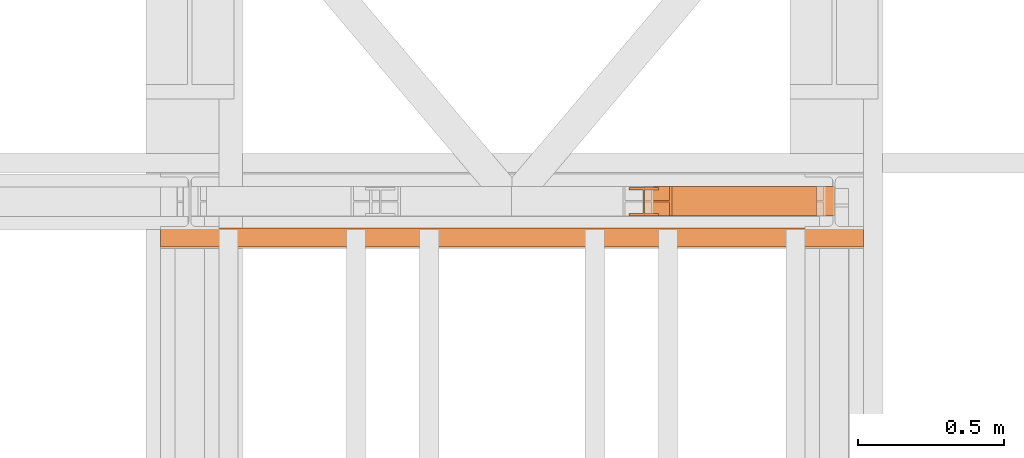
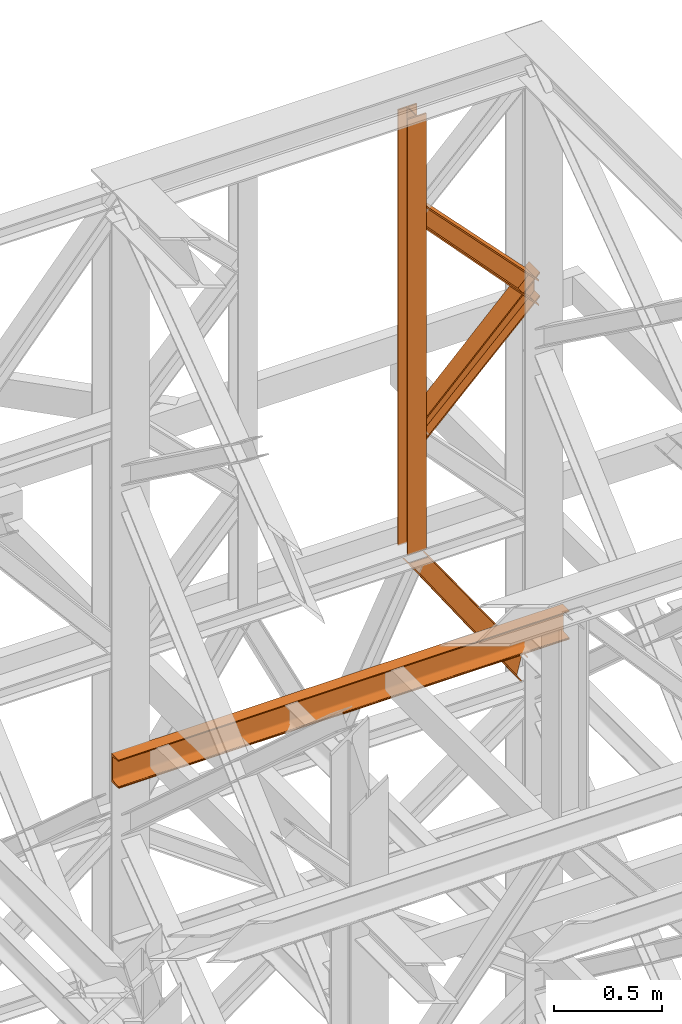
# One storey, part 188 of 208: 5 proxies.
"""IFC2X3 building model written with IfcOpenShell, lengths in millimetres."""

from ifc_helpers import new_model, entity, si_unit, converted_unit, frame, origin, origin_with_axes, place, context, subcontext, project, spatial, faceted_brep, element, save


model = new_model("IFC2X3")

# Units and contexts
model_context = context("Model", 3, precision=1e-05, world=origin())
plan_context = context("Plan", 3, precision=1e-05, world=origin())
body_context = subcontext(model_context, "Body", "Model", "MODEL_VIEW")
ifc_project = project(units=[si_unit("LENGTHUNIT", "METRE", prefix="MILLI"), converted_unit("PLANEANGLEUNIT", "DEGREE", entity("IfcPlaneAngleMeasure", 0.0174532925199433), si_unit("PLANEANGLEUNIT", "RADIAN"), dimensions=[0, 0, 0, 0, 0, 0, 0]), si_unit("AREAUNIT", "SQUARE_METRE"), si_unit("VOLUMEUNIT", "CUBIC_METRE")], contexts=[model_context, plan_context])

# Building, storey
building_placement = place(None, origin())
building = spatial("IfcBuilding", under=ifc_project, at=building_placement, CompositionType="COMPLEX")
storey_placement = place(building_placement, origin_with_axes())
storey = spatial("IfcBuildingStorey", under=building, at=storey_placement, Name="Geschoss", CompositionType="ELEMENT")

# Proxies
proxy_1_placement = place(storey_placement, frame((8093.254968528663, -13810.57439404318, 9798.105713222345), z_axis=(0.0, 0.0, 1.0), x_axis=(1.0, 0.0, 0.0)))
element("IfcBuildingElementProxy", 1, at=proxy_1_placement, inside=storey, context=body_context, shape_type="Brep", body=[
    faceted_brep([(100.0100000000039, 88.01000000000022, 0.01000000000021828), (100.0100000000039, 96.01000000000022, 0.01000000000021828), (0.01000000000385626, 96.01000000000022, 0.01000000000021828), (0.01000000000385626, 88.01000000000022, 0.01000000000021828), (47.51000000000386, 88.01000000000022, 0.01000000000021828), (47.51000000000386, 8.010000000000218, 0.01000000000021828), (0.01000000000385626, 8.010000000000218, 0.01000000000021828), (0.01000000000385626, 0.01000000000021828, 0.01000000000021828), (100.0100000000039, 0.01000000000021828, 0.01000000000021828), (100.0100000000039, 8.010000000000218, 0.01000000000021828), (52.51000000000386, 8.010000000000218, 0.01000000000021828), (52.51000000000386, 88.01000000000022, 0.01000000000021828), (100.0100000000039, 96.01000000000022, 0.01000000000021828), (100.0100000000039, 88.01000000000022, 0.01000000000021828), (100.0100000000002, 88.01000000000022, 2451.894345471463), (100.0100000000002, 96.01000000000022, 2451.894345471463), (0.01000000000385626, 96.01000000000022, 0.01000000000021828), (100.0100000000039, 96.01000000000022, 0.01000000000021828), (100.0100000000002, 96.01000000000022, 2451.894345471463), (0.01000000000021828, 96.01000000000022, 2451.894345471463), (0.01000000000385626, 88.01000000000022, 0.01000000000021828), (0.01000000000385626, 96.01000000000022, 0.01000000000021828), (0.01000000000021828, 96.01000000000022, 2451.894345471463), (0.01000000000021828, 88.01000000000022, 2451.894345471463), (47.51000000000386, 88.01000000000022, 0.01000000000021828), (0.01000000000385626, 88.01000000000022, 0.01000000000021828), (0.01000000000021828, 88.01000000000022, 2451.894345471463), (47.51000000000022, 88.01000000000022, 2451.894345471463), (47.51000000000386, 8.010000000000218, 0.01000000000021828), (47.51000000000386, 88.01000000000022, 0.01000000000021828), (47.51000000000022, 88.01000000000022, 2451.894345471463), (47.51000000000022, 8.010000000000218, 2451.894345471463), (0.01000000000385626, 8.010000000000218, 0.01000000000021828), (47.51000000000386, 8.010000000000218, 0.01000000000021828), (47.51000000000022, 8.010000000000218, 2451.894345471463), (0.01000000000021828, 8.010000000000218, 2451.894345471463), (0.01000000000385626, 0.01000000000021828, 0.01000000000021828), (0.01000000000385626, 8.010000000000218, 0.01000000000021828), (0.01000000000021828, 8.010000000000218, 2451.894345471463), (0.01000000000021828, 0.01000000000021828, 2451.894345471463), (100.0100000000039, 0.01000000000021828, 0.01000000000021828), (0.01000000000385626, 0.01000000000021828, 0.01000000000021828), (0.01000000000021828, 0.01000000000021828, 2451.894345471463), (100.0100000000002, 0.01000000000021828, 2451.894345471463), (100.0100000000039, 8.010000000000218, 0.01000000000021828), (100.0100000000039, 0.01000000000021828, 0.01000000000021828), (100.0100000000002, 0.01000000000021828, 2451.894345471463), (100.0100000000002, 8.010000000000218, 2451.894345471463), (52.51000000000386, 8.010000000000218, 0.01000000000021828), (100.0100000000039, 8.010000000000218, 0.01000000000021828), (100.0100000000002, 8.010000000000218, 2451.894345471463), (52.51000000000022, 8.010000000000218, 2451.894345471463), (52.51000000000386, 88.01000000000022, 0.01000000000021828), (52.51000000000386, 8.010000000000218, 0.01000000000021828), (52.51000000000022, 8.010000000000218, 2451.894345471463), (52.51000000000022, 88.01000000000022, 2451.894345471463), (100.0100000000039, 88.01000000000022, 0.01000000000021828), (52.51000000000386, 88.01000000000022, 0.01000000000021828), (52.51000000000022, 88.01000000000022, 2451.894345471463), (100.0100000000002, 88.01000000000022, 2451.894345471463), (100.0100000000002, 88.01000000000022, 2451.894345471463), (52.51000000000022, 88.01000000000022, 2451.894345471463), (52.51000000000022, 8.010000000000218, 2451.894345471463), (100.0100000000002, 8.010000000000218, 2451.894345471463), (100.0100000000002, 0.01000000000021828, 2451.894345471463), (0.01000000000021828, 0.01000000000021828, 2451.894345471463), (0.01000000000021828, 8.010000000000218, 2451.894345471463), (47.51000000000022, 8.010000000000218, 2451.894345471463), (47.51000000000022, 88.01000000000022, 2451.894345471463), (0.01000000000021828, 88.01000000000022, 2451.894345471463), (0.01000000000021828, 96.01000000000022, 2451.894345471463), (100.0100000000002, 96.01000000000022, 2451.894345471463)], [[[0, 1, 2, 3, 4, 5, 6, 7, 8, 9, 10, 11]], [[12, 13, 14, 15]], [[16, 17, 18, 19]], [[20, 21, 22, 23]], [[24, 25, 26, 27]], [[28, 29, 30, 31]], [[32, 33, 34, 35]], [[36, 37, 38, 39]], [[40, 41, 42, 43]], [[44, 45, 46, 47]], [[48, 49, 50, 51]], [[52, 53, 54, 55]], [[56, 57, 58, 59]], [[60, 61, 62, 63, 64, 65, 66, 67, 68, 69, 70, 71]]], orient=[[False], [False], [False], [False], [False], [False], [False], [False], [False], [False], [False], [False], [False], [False]]),
])
proxy_2_placement = place(storey_placement, frame((8145.754968528665, -13810.57439404318, 10955.2185593949), z_axis=(0.0, 0.0, 1.0), x_axis=(1.0, 0.0, 0.0)))
element("IfcBuildingElementProxy", 2, at=proxy_2_placement, inside=storey, context=body_context, shape_type="Brep", body=[
    faceted_brep([(647.5100014901182, 0.01000000000021828, 136.1559367639657), (0.01000000000203727, 0.01000000000021828, 810.8787261814559), (0.01000000000203727, 0.01000000000021828, 821.3321792650186), (647.5100014901182, 0.01000000000021828, 145.6651963377171), (647.5100014901182, 0.01000000000021828, 145.6651963377171), (0.01000000000203727, 0.01000000000021828, 821.3321792650186), (0.01000000000112777, 100.0100000000002, 821.3321792650258), (647.5100014901163, 100.0100000000002, 145.6651963377208), (647.5100014901163, 100.0100000000002, 145.6651963377208), (0.01000000000112777, 100.0100000000002, 821.3321792650258), (0.01000000000203727, 100.0100000000002, 810.8787261814559), (647.5100014901182, 100.0100000000002, 136.1559367639657), (647.5100014901182, 100.0100000000002, 136.1559367639657), (0.01000000000203727, 100.0100000000002, 810.8787261814559), (0.01000000000294676, 52.51000000000022, 810.8787261814559), (647.5100014901145, 52.51000000000022, 136.1559367639693), (647.5100014901145, 52.51000000000022, 136.1559367639693), (0.01000000000294676, 52.51000000000022, 810.8787261814559), (0.01000000000203727, 52.51000000000022, 700.4756203415545), (647.5100014901182, 52.51000000000022, 9.52026454738916), (647.5100014901182, 52.51000000000022, 9.52026454738916), (0.01000000000203727, 52.51000000000022, 700.4756203415545), (0.009999999999308784, 100.0100000000002, 700.4756203415545), (647.51000149012, 100.0100000000002, 9.520264547385523), (647.51000149012, 100.0100000000002, 9.520264547385523), (0.009999999999308784, 100.0100000000002, 700.4756203415545), (0.01000000000203727, 100.0100000000002, 690.0159394275852), (647.5100014901182, 100.0100000000002, 0.01000000000021828), (647.5100014901182, 100.0100000000002, 0.01000000000021828), (0.01000000000203727, 100.0100000000002, 690.0159394275852), (0.01000000000203727, 0.01000000000021828, 690.0159394275852), (647.5100014901182, 0.01000000000021828, 0.01000000000021828), (647.5100014901182, 0.01000000000021828, 0.01000000000021828), (0.01000000000203727, 0.01000000000021828, 690.0159394275852), (0.01000000000203727, 0.01000000000021828, 700.4756203415545), (647.5100014901182, 0.01000000000021828, 9.520264547392799), (647.5100014901182, 0.01000000000021828, 9.520264547392799), (0.01000000000203727, 0.01000000000021828, 700.4756203415545), (0.01000000000112777, 47.51000000000022, 700.4756203415545), (647.51000149012, 47.51000000000022, 9.520264547392799), (647.51000149012, 47.51000000000022, 9.520264547392799), (0.01000000000112777, 47.51000000000022, 700.4756203415545), (0.01000000000203727, 47.51000000000022, 810.8787261814559), (647.5100014901182, 47.51000000000022, 136.1559367639657), (647.5100014901182, 47.51000000000022, 136.1559367639657), (0.01000000000203727, 47.51000000000022, 810.8787261814559), (0.01000000000203727, 0.01000000000021828, 810.8787261814559), (647.5100014901182, 0.01000000000021828, 136.1559367639657), (0.01000000000203727, 0.01000000000021828, 810.8787261814559), (0.01000000000203727, 47.51000000000022, 810.8787261814559), (0.01000000000112777, 47.51000000000022, 700.4756203415545), (0.01000000000203727, 0.01000000000021828, 700.4756203415545), (0.01000000000203727, 0.01000000000021828, 690.0159394275852), (0.01000000000203727, 100.0100000000002, 690.0159394275852), (0.009999999999308784, 100.0100000000002, 700.4756203415545), (0.01000000000203727, 52.51000000000022, 700.4756203415545), (0.01000000000294676, 52.51000000000022, 810.8787261814559), (0.01000000000203727, 100.0100000000002, 810.8787261814559), (0.01000000000112777, 100.0100000000002, 821.3321792650258), (0.01000000000203727, 0.01000000000021828, 821.3321792650186), (647.5100014901182, 0.01000000000021828, 145.6651963377171), (647.5100014901163, 100.0100000000002, 145.6651963377208), (647.5100014901182, 100.0100000000002, 136.1559367639657), (647.5100014901145, 52.51000000000022, 136.1559367639693), (647.5100014901182, 52.51000000000022, 9.52026454738916), (647.51000149012, 100.0100000000002, 9.520264547385523), (647.5100014901182, 100.0100000000002, 0.01000000000021828), (647.5100014901182, 0.01000000000021828, 0.01000000000021828), (647.5100014901182, 0.01000000000021828, 9.520264547392799), (647.51000149012, 47.51000000000022, 9.520264547392799), (647.5100014901182, 47.51000000000022, 136.1559367639657), (647.5100014901182, 0.01000000000021828, 136.1559367639657)], [[[0, 1, 2, 3]], [[4, 5, 6, 7]], [[8, 9, 10, 11]], [[12, 13, 14, 15]], [[16, 17, 18, 19]], [[20, 21, 22, 23]], [[24, 25, 26, 27]], [[28, 29, 30, 31]], [[32, 33, 34, 35]], [[36, 37, 38, 39]], [[40, 41, 42, 43]], [[44, 45, 46, 47]], [[48, 49, 50, 51, 52, 53, 54, 55, 56, 57, 58, 59]], [[60, 61, 62, 63, 64, 65, 66, 67, 68, 69, 70, 71]]], orient=[[False], [False], [False], [False], [False], [False], [False], [False], [False], [False], [False], [False], [False], [False]]),
])
proxy_3_placement = place(storey_placement, frame((8143.254968528662, -13810.57439404318, 10364.55433028874), z_axis=(0.0, 0.0, 1.0), x_axis=(1.0, 0.0, 0.0)))
element("IfcBuildingElementProxy", 3, at=proxy_3_placement, inside=storey, context=body_context, shape_type="Brep", body=[
    faceted_brep([(653.26000006706, 0.01000000000021828, 771.736684541449), (0.01000000000294676, 0.01000000000021828, 117.0703501202133), (0.01000000000203727, 0.01000000000021828, 127.2232754441011), (653.26000006706, 0.01000000000021828, 780.9755634240846), (653.26000006706, 0.01000000000021828, 780.9755634240846), (0.01000000000203727, 0.01000000000021828, 127.2232754441011), (0.01000000000021828, 100.0100000000002, 127.2232754441011), (653.26000006706, 100.0100000000002, 780.9755634240883), (653.26000006706, 100.0100000000002, 780.9755634240883), (0.01000000000021828, 100.0100000000002, 127.2232754441011), (0.01000000000294676, 100.0100000000002, 117.0703501202133), (653.26000006706, 100.0100000000002, 771.7366845414454), (653.26000006706, 100.0100000000002, 771.7366845414454), (0.01000000000294676, 100.0100000000002, 117.0703501202133), (0.01000000000112777, 52.51000000000022, 117.0703501202133), (653.2600000670654, 52.51000000000022, 771.7366845414526), (653.2600000670654, 52.51000000000022, 771.7366845414526), (0.01000000000112777, 52.51000000000022, 117.0703501202133), (0.01000000000294676, 52.51000000000022, 10.10333120962423), (653.26000006706, 52.51000000000022, 649.4102960638211), (653.26000006706, 52.51000000000022, 649.4102960638211), (0.01000000000294676, 52.51000000000022, 10.10333120962423), (0.01000000000294676, 100.0100000000002, 10.10333120962787), (653.26000006706, 100.0100000000002, 649.4102960638247), (653.26000006706, 100.0100000000002, 649.4102960638247), (0.01000000000294676, 100.0100000000002, 10.10333120962787), (0.01000000000203727, 100.0100000000002, 0.01000000000385626), (653.26000006706, 100.0100000000002, 640.194998598121), (653.26000006706, 100.0100000000002, 640.194998598121), (0.01000000000203727, 100.0100000000002, 0.01000000000385626), (0.01000000000294676, 0.01000000000021828, 0.01000000000021828), (653.26000006706, 0.01000000000021828, 640.194998598121), (653.26000006706, 0.01000000000021828, 640.194998598121), (0.01000000000294676, 0.01000000000021828, 0.01000000000021828), (0.01000000000294676, 0.01000000000021828, 10.10333120962423), (653.26000006706, 0.01000000000021828, 649.4102960638247), (653.26000006706, 0.01000000000021828, 649.4102960638247), (0.01000000000294676, 0.01000000000021828, 10.10333120962423), (0.01000000000294676, 47.51000000000022, 10.10333120962787), (653.26000006706, 47.51000000000022, 649.4102960638284), (653.26000006706, 47.51000000000022, 649.4102960638284), (0.01000000000294676, 47.51000000000022, 10.10333120962787), (0.01000000000294676, 47.51000000000022, 117.0703501202133), (653.26000006706, 47.51000000000022, 771.7366845414454), (653.26000006706, 47.51000000000022, 771.7366845414454), (0.01000000000294676, 47.51000000000022, 117.0703501202133), (0.01000000000294676, 0.01000000000021828, 117.0703501202133), (653.26000006706, 0.01000000000021828, 771.736684541449), (0.01000000000294676, 0.01000000000021828, 117.0703501202133), (0.01000000000294676, 47.51000000000022, 117.0703501202133), (0.01000000000294676, 47.51000000000022, 10.10333120962787), (0.01000000000294676, 0.01000000000021828, 10.10333120962423), (0.01000000000294676, 0.01000000000021828, 0.01000000000021828), (0.01000000000203727, 100.0100000000002, 0.01000000000385626), (0.01000000000294676, 100.0100000000002, 10.10333120962787), (0.01000000000294676, 52.51000000000022, 10.10333120962423), (0.01000000000112777, 52.51000000000022, 117.0703501202133), (0.01000000000294676, 100.0100000000002, 117.0703501202133), (0.01000000000021828, 100.0100000000002, 127.2232754441011), (0.01000000000203727, 0.01000000000021828, 127.2232754441011), (653.26000006706, 0.01000000000021828, 780.9755634240846), (653.26000006706, 100.0100000000002, 780.9755634240883), (653.26000006706, 100.0100000000002, 771.7366845414454), (653.2600000670654, 52.51000000000022, 771.7366845414526), (653.26000006706, 52.51000000000022, 649.4102960638211), (653.26000006706, 100.0100000000002, 649.4102960638247), (653.26000006706, 100.0100000000002, 640.194998598121), (653.26000006706, 0.01000000000021828, 640.194998598121), (653.26000006706, 0.01000000000021828, 649.4102960638247), (653.26000006706, 47.51000000000022, 649.4102960638284), (653.26000006706, 47.51000000000022, 771.7366845414454), (653.26000006706, 0.01000000000021828, 771.736684541449)], [[[0, 1, 2, 3]], [[4, 5, 6, 7]], [[8, 9, 10, 11]], [[12, 13, 14, 15]], [[16, 17, 18, 19]], [[20, 21, 22, 23]], [[24, 25, 26, 27]], [[28, 29, 30, 31]], [[32, 33, 34, 35]], [[36, 37, 38, 39]], [[40, 41, 42, 43]], [[44, 45, 46, 47]], [[48, 49, 50, 51, 52, 53, 54, 55, 56, 57, 58, 59]], [[60, 61, 62, 63, 64, 65, 66, 67, 68, 69, 70, 71]]], orient=[[False], [False], [False], [False], [False], [False], [False], [False], [False], [False], [False], [False], [False], [False]]),
])
proxy_4_placement = place(storey_placement, frame((8123.735345452011, -13810.57439404318, 8872.310477686953), z_axis=(0.0, 0.0, 1.0), x_axis=(1.0, 0.0, 0.0)))
element("IfcBuildingElementProxy", 4, at=proxy_4_placement, inside=storey, context=body_context, shape_type="Brep", body=[
    faceted_brep([(607.5719637014772, 0.01000000000021828, 123.6259631817866), (107.9757067031351, 0.01000000000021828, 837.8052355353921), (116.3342395072832, 0.01000000000021828, 837.8052355353921), (609.6918638003717, 0.01000000000021828, 131.7181462696044), (609.6918638003717, 0.01000000000021828, 131.7181462696044), (116.3342395072832, 0.01000000000021828, 837.8052355353921), (116.3342395072796, 100.0100000000002, 837.8052355353921), (609.6918638003717, 100.0100000000002, 131.7181462696044), (609.6918638003717, 100.0100000000002, 131.7181462696044), (116.3342395072796, 100.0100000000002, 837.8052355353921), (107.9757067031351, 100.0100000000002, 837.8052355353921), (607.5719637014772, 100.0100000000002, 123.6259631817866), (607.5719637014772, 100.0100000000002, 123.6259631817866), (107.9757067031351, 100.0100000000002, 837.8052355353921), (107.9757067031333, 52.51000000000022, 837.8052355353921), (607.5719637014772, 52.51000000000022, 123.6259631817866), (607.5719637014772, 52.51000000000022, 123.6259631817866), (107.9757067031333, 52.51000000000022, 837.8052355353921), (8.346467362069234, 52.51000000000022, 837.8052355353921), (577.3079429277404, 52.51000000000022, 8.100709325468415), (577.3079429277404, 52.51000000000022, 8.100709325468415), (8.346467362069234, 52.51000000000022, 837.8052355353921), (8.346467362072872, 100.0100000000002, 837.8052355353921), (577.3079429277404, 100.0100000000002, 8.100709325472053), (577.3079429277404, 100.0100000000002, 8.100709325472053), (8.346467362072872, 100.0100000000002, 837.8052355353921), (0.01000000000203727, 100.0100000000002, 837.8052355353921), (575.188428908712, 100.0100000000002, 0.01000000000021828), (575.188428908712, 100.0100000000002, 0.01000000000021828), (0.01000000000203727, 100.0100000000002, 837.8052355353921), (0.01000000000021828, 0.01000000000021828, 837.8052355353921), (575.188428908712, 0.01000000000021828, 0.01000000000021828), (575.188428908712, 0.01000000000021828, 0.01000000000021828), (0.01000000000021828, 0.01000000000021828, 837.8052355353921), (8.34646736207469, 0.01000000000021828, 837.8052355353921), (577.3079429277404, 0.01000000000021828, 8.100709325472053), (577.3079429277404, 0.01000000000021828, 8.100709325472053), (8.34646736207469, 0.01000000000021828, 837.8052355353921), (8.346467362072872, 47.51000000000022, 837.8052355353884), (577.3079429277423, 47.51000000000022, 8.100709325475691), (577.3079429277423, 47.51000000000022, 8.100709325475691), (8.346467362072872, 47.51000000000022, 837.8052355353884), (107.9757067031351, 47.51000000000022, 837.8052355353921), (607.5719637014772, 47.51000000000022, 123.6259631817866), (607.5719637014772, 47.51000000000022, 123.6259631817866), (107.9757067031351, 47.51000000000022, 837.8052355353921), (107.9757067031351, 0.01000000000021828, 837.8052355353921), (607.5719637014772, 0.01000000000021828, 123.6259631817866), (609.6918638003717, 0.01000000000021828, 131.7181462696044), (609.6918638003717, 100.0100000000002, 131.7181462696044), (607.5719637014772, 100.0100000000002, 123.6259631817866), (607.5719637014772, 52.51000000000022, 123.6259631817866), (577.3079429277404, 52.51000000000022, 8.100709325468415), (577.3079429277404, 100.0100000000002, 8.100709325472053), (575.188428908712, 100.0100000000002, 0.01000000000021828), (575.188428908712, 0.01000000000021828, 0.01000000000021828), (577.3079429277404, 0.01000000000021828, 8.100709325472053), (577.3079429277423, 47.51000000000022, 8.100709325475691), (607.5719637014772, 47.51000000000022, 123.6259631817866), (607.5719637014772, 0.01000000000021828, 123.6259631817866), (107.9757067031351, 0.01000000000021828, 837.8052355353921), (107.9757067031351, 47.51000000000022, 837.8052355353921), (8.346467362072872, 47.51000000000022, 837.8052355353884), (8.34646736207469, 0.01000000000021828, 837.8052355353921), (0.01000000000021828, 0.01000000000021828, 837.8052355353921), (0.01000000000203727, 100.0100000000002, 837.8052355353921), (8.346467362072872, 100.0100000000002, 837.8052355353921), (8.346467362069234, 52.51000000000022, 837.8052355353921), (107.9757067031333, 52.51000000000022, 837.8052355353921), (107.9757067031351, 100.0100000000002, 837.8052355353921), (116.3342395072796, 100.0100000000002, 837.8052355353921), (116.3342395072832, 0.01000000000021828, 837.8052355353921)], [[[0, 1, 2, 3]], [[4, 5, 6, 7]], [[8, 9, 10, 11]], [[12, 13, 14, 15]], [[16, 17, 18, 19]], [[20, 21, 22, 23]], [[24, 25, 26, 27]], [[28, 29, 30, 31]], [[32, 33, 34, 35]], [[36, 37, 38, 39]], [[40, 41, 42, 43]], [[44, 45, 46, 47]], [[48, 49, 50, 51, 52, 53, 54, 55, 56, 57, 58, 59]], [[60, 61, 62, 63, 64, 65, 66, 67, 68, 69, 70, 71]]], orient=[[False], [False], [False], [False], [False], [False], [False], [False], [False], [False], [False], [False], [False], [False]]),
])
proxy_5_placement = place(storey_placement, frame((6493.302372304859, -13917.58293324866, 9109.989999999998), z_axis=(0.0, 0.0, 1.0), x_axis=(1.0, 0.0, 0.0)))
element("IfcBuildingElementProxy", 5, at=proxy_5_placement, inside=storey, context=body_context, shape_type="Brep", body=[
    faceted_brep([(2399.962597713924, 65.01000000000022, 160.0100000000002), (2399.962597713924, 0.01000000000021828, 160.0100000000002), (0.01000000000021828, 0.01853275732901238, 160.0100000000002), (0.01000000000021828, 65.01853275732901, 160.0100000000002), (2399.962597713924, 0.01000000000021828, 160.0100000000002), (2399.962597713924, 0.01000000000021828, 156.8875719297539), (0.01000000000021828, 0.01853275732901238, 156.8875719297539), (0.01000000000021828, 0.01853275732901238, 160.0100000000002), (2399.962597713924, 0.01000000000021828, 156.8875719297539), (2399.962597713924, 0.2527365771729819, 155.2717110918293), (0.01000000000021828, 0.261269334501776, 155.2717110918293), (0.01000000000021828, 0.01853275732901238, 156.8875719297539), (2399.962597713924, 0.2527365771729819, 155.2717110918293), (2399.962597713924, 0.959467714144921, 153.7984655565542), (0.01000000000021828, 0.9680004714700772, 153.7984655565542), (0.01000000000021828, 0.261269334501776, 155.2717110918293), (2399.962597713924, 0.959467714144921, 153.7984655565542), (2399.962597713924, 2.067848361532015, 152.5978732961266), (0.01000000000021828, 2.076381118860809, 152.5978732961266), (0.01000000000021828, 0.9680004714700772, 153.7984655565542), (2399.962597713924, 2.067848361532015, 152.5978732961266), (2399.962597713924, 3.480043588517219, 151.7759086082897), (0.01000000000021828, 3.488576345846013, 151.7759086082897), (0.01000000000021828, 2.076381118860809, 152.5978732961266), (2399.962597713924, 3.480043588517219, 151.7759086082897), (2399.962597713924, 5.071401277446057, 151.4050878978051), (0.01000000000021828, 5.079934034774851, 151.4050878978051), (0.01000000000021828, 3.488576345846013, 151.7759086082897), (2399.962597713924, 5.071401277446057, 151.4050878978051), (2399.962597713924, 47.84732483397056, 147.9830140132835), (0.01000000000021828, 47.85585759129936, 147.9830140132835), (0.01000000000021828, 5.079934034774851, 151.4050878978051), (2399.962597713924, 47.84732483397056, 147.9830140132835), (2399.962597713924, 50.8115917919913, 147.318026761528), (0.01000000000021828, 50.8201245493201, 147.318026761528), (0.01000000000021828, 47.85585759129936, 147.9830140132835), (2399.962597713924, 50.8115917919913, 147.318026761528), (2399.962597713924, 53.5813804007139, 145.7058782528511), (0.01000000000021828, 53.58991315803905, 145.7058782528511), (0.01000000000021828, 50.8201245493201, 147.318026761528), (2399.962597713924, 53.5813804007139, 145.7058782528511), (2399.962597713924, 55.69737981845356, 143.4138384829421), (0.01000000000021828, 55.70591257578235, 143.4138384829421), (0.01000000000021828, 53.58991315803905, 145.7058782528511), (2399.962597713924, 55.69737981845356, 143.4138384829421), (2399.962597713924, 57.04659380721387, 140.6012788246917), (0.01000000000021828, 57.05512656454266, 140.6012788246917), (0.01000000000021828, 55.70591257578235, 143.4138384829421), (2399.962597713924, 57.04659380721387, 140.6012788246917), (2399.962597713924, 57.51000000000022, 137.5164535886543), (0.01000000000021828, 57.51853275732901, 137.5164535886543), (0.01000000000021828, 57.05512656454266, 140.6012788246917), (2399.962597713924, 57.51000000000022, 137.5164535886543), (2399.962597713924, 57.51000000000022, 22.503546411348), (0.01000000000021828, 57.51853275732901, 22.503546411348), (0.01000000000021828, 57.51853275732901, 137.5164535886543), (2399.962597713924, 57.51000000000022, 22.503546411348), (2399.962597713924, 57.04659380721387, 19.41872117530875), (0.01000000000021828, 57.05512656454266, 19.41872117530875), (0.01000000000021828, 57.51853275732901, 22.503546411348), (2399.962597713924, 57.04659380721387, 19.41872117530875), (2399.962597713924, 55.69737981845356, 16.60616151705835), (0.01000000000021828, 55.70591257578235, 16.60616151705835), (0.01000000000021828, 57.05512656454266, 19.41872117530875), (2399.962597713924, 55.69737981845356, 16.60616151705835), (2399.962597713924, 53.5813804007139, 14.31412174714933), (0.01000000000021828, 53.58991315803905, 14.31412174714933), (0.01000000000021828, 55.70591257578235, 16.60616151705835), (2399.962597713924, 53.5813804007139, 14.31412174714933), (2399.962597713924, 50.88537133101818, 12.74491643400688), (0.01000000000021828, 50.89390408834333, 12.74491643400688), (0.01000000000021828, 53.58991315803905, 14.31412174714933), (2399.962597713924, 50.88537133101818, 12.74491643400688), (2399.962597713924, 47.84732483397056, 12.03698598671872), (0.01000000000021828, 47.85585759129936, 12.03698598671872), (0.01000000000021828, 50.89390408834333, 12.74491643400688), (2399.962597713924, 47.84732483397056, 12.03698598671872), (2399.962597713924, 5.071401277446057, 8.614912102195376), (0.01000000000021828, 5.079934034774851, 8.614912102195376), (0.01000000000021828, 47.85585759129936, 12.03698598671872), (2399.962597713924, 5.071401277446057, 8.614912102195376), (2399.962597713924, 3.480043588517219, 8.244091391710754), (0.01000000000021828, 3.488576345846013, 8.244091391710754), (0.01000000000021828, 5.079934034774851, 8.614912102195376), (2399.962597713924, 3.480043588517219, 8.244091391710754), (2399.962597713924, 2.067848361532015, 7.422126703873801), (0.01000000000021828, 2.076381118860809, 7.422126703873801), (0.01000000000021828, 3.488576345846013, 8.244091391710754), (2399.962597713924, 2.067848361532015, 7.422126703873801), (2399.962597713924, 0.959467714144921, 6.221534443446217), (0.01000000000021828, 0.9680004714700772, 6.221534443446217), (0.01000000000021828, 2.076381118860809, 7.422126703873801), (2399.962597713924, 0.959467714144921, 6.221534443446217), (2399.962597713924, 0.2527365771729819, 4.748288908172981), (0.01000000000021828, 0.261269334501776, 4.748288908172981), (0.01000000000021828, 0.9680004714700772, 6.221534443446217), (2399.962597713924, 0.2527365771729819, 4.748288908172981), (2399.962597713924, 0.01000000000021828, 0.01000000000021828), (0.01000000000021828, 0.01853275732901238, 0.01000000000021828), (0.01000000000021828, 0.261269334501776, 4.748288908172981), (2399.962597713924, 0.01000000000021828, 0.01000000000021828), (2399.962597713924, 65.01000000000022, 0.01000000000021828), (0.01000000000021828, 65.01853275732901, 0.01000000000021828), (0.01000000000021828, 0.01853275732901238, 0.01000000000021828), (2399.962597713924, 65.01000000000022, 0.01000000000021828), (2399.962597713924, 65.01000000000022, 160.0100000000002), (0.01000000000021828, 65.01853275732901, 160.0100000000002), (0.01000000000021828, 65.01853275732901, 0.01000000000021828), (2399.962597713924, 65.01000000000022, 160.0100000000002), (2399.962597713924, 65.01000000000022, 0.01000000000021828), (2399.962597713924, 0.01000000000021828, 0.01000000000021828), (2399.962597713924, 0.2527365771729819, 4.748288908172981), (2399.962597713924, 0.959467714144921, 6.221534443446217), (2399.962597713924, 2.067848361532015, 7.422126703873801), (2399.962597713924, 3.480043588517219, 8.244091391710754), (2399.962597713924, 5.071401277446057, 8.614912102195376), (2399.962597713924, 47.84732483397056, 12.03698598671872), (2399.962597713924, 50.88537133101818, 12.74491643400688), (2399.962597713924, 53.5813804007139, 14.31412174714933), (2399.962597713924, 55.69737981845356, 16.60616151705835), (2399.962597713924, 57.04659380721387, 19.41872117530875), (2399.962597713924, 57.51000000000022, 22.503546411348), (2399.962597713924, 57.51000000000022, 137.5164535886543), (2399.962597713924, 57.04659380721387, 140.6012788246917), (2399.962597713924, 55.69737981845356, 143.4138384829421), (2399.962597713924, 53.5813804007139, 145.7058782528511), (2399.962597713924, 50.8115917919913, 147.318026761528), (2399.962597713924, 47.84732483397056, 147.9830140132835), (2399.962597713924, 5.071401277446057, 151.4050878978051), (2399.962597713924, 3.480043588517219, 151.7759086082897), (2399.962597713924, 2.067848361532015, 152.5978732961266), (2399.962597713924, 0.959467714144921, 153.7984655565542), (2399.962597713924, 0.2527365771729819, 155.2717110918293), (2399.962597713924, 0.01000000000021828, 156.8875719297539), (2399.962597713924, 0.01000000000021828, 160.0100000000002), (0.01000000000021828, 65.01853275732901, 160.0100000000002), (0.01000000000021828, 0.01853275732901238, 160.0100000000002), (0.01000000000021828, 0.01853275732901238, 156.8875719297539), (0.01000000000021828, 0.261269334501776, 155.2717110918293), (0.01000000000021828, 0.9680004714700772, 153.7984655565542), (0.01000000000021828, 2.076381118860809, 152.5978732961266), (0.01000000000021828, 3.488576345846013, 151.7759086082897), (0.01000000000021828, 5.079934034774851, 151.4050878978051), (0.01000000000021828, 47.85585759129936, 147.9830140132835), (0.01000000000021828, 50.8201245493201, 147.318026761528), (0.01000000000021828, 53.58991315803905, 145.7058782528511), (0.01000000000021828, 55.70591257578235, 143.4138384829421), (0.01000000000021828, 57.05512656454266, 140.6012788246917), (0.01000000000021828, 57.51853275732901, 137.5164535886543), (0.01000000000021828, 57.51853275732901, 22.503546411348), (0.01000000000021828, 57.05512656454266, 19.41872117530875), (0.01000000000021828, 55.70591257578235, 16.60616151705835), (0.01000000000021828, 53.58991315803905, 14.31412174714933), (0.01000000000021828, 50.89390408834333, 12.74491643400688), (0.01000000000021828, 47.85585759129936, 12.03698598671872), (0.01000000000021828, 5.079934034774851, 8.614912102195376), (0.01000000000021828, 3.488576345846013, 8.244091391710754), (0.01000000000021828, 2.076381118860809, 7.422126703873801), (0.01000000000021828, 0.9680004714700772, 6.221534443446217), (0.01000000000021828, 0.261269334501776, 4.748288908172981), (0.01000000000021828, 0.01853275732901238, 0.01000000000021828), (0.01000000000021828, 65.01853275732901, 0.01000000000021828)], [[[0, 1, 2, 3]], [[4, 5, 6, 7]], [[8, 9, 10, 11]], [[12, 13, 14, 15]], [[16, 17, 18, 19]], [[20, 21, 22, 23]], [[24, 25, 26, 27]], [[28, 29, 30, 31]], [[32, 33, 34, 35]], [[36, 37, 38, 39]], [[40, 41, 42, 43]], [[44, 45, 46, 47]], [[48, 49, 50, 51]], [[52, 53, 54, 55]], [[56, 57, 58, 59]], [[60, 61, 62, 63]], [[64, 65, 66, 67]], [[68, 69, 70, 71]], [[72, 73, 74, 75]], [[76, 77, 78, 79]], [[80, 81, 82, 83]], [[84, 85, 86, 87]], [[88, 89, 90, 91]], [[92, 93, 94, 95]], [[96, 97, 98, 99]], [[100, 101, 102, 103]], [[104, 105, 106, 107]], [[108, 109, 110, 111, 112, 113, 114, 115, 116, 117, 118, 119, 120, 121, 122, 123, 124, 125, 126, 127, 128, 129, 130, 131, 132, 133, 134]], [[135, 136, 137, 138, 139, 140, 141, 142, 143, 144, 145, 146, 147, 148, 149, 150, 151, 152, 153, 154, 155, 156, 157, 158, 159, 160, 161]]], orient=[[False], [False], [False], [False], [False], [False], [False], [False], [False], [False], [False], [False], [False], [False], [False], [False], [False], [False], [False], [False], [False], [False], [False], [False], [False], [False], [False], [False], [False]]),
])

save(model, "model.ifc")
